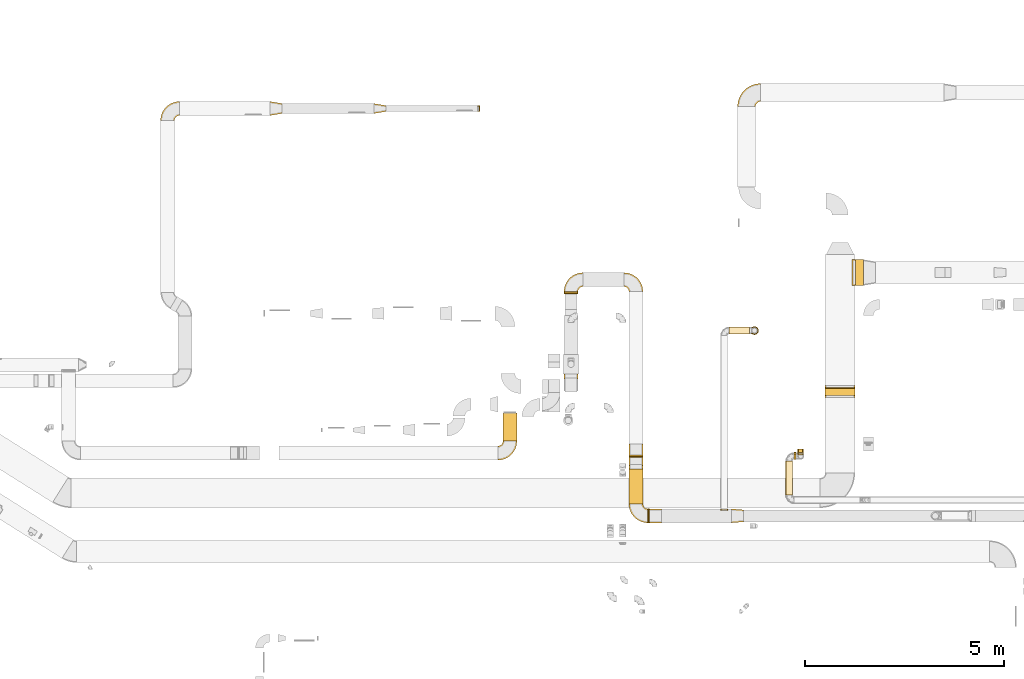
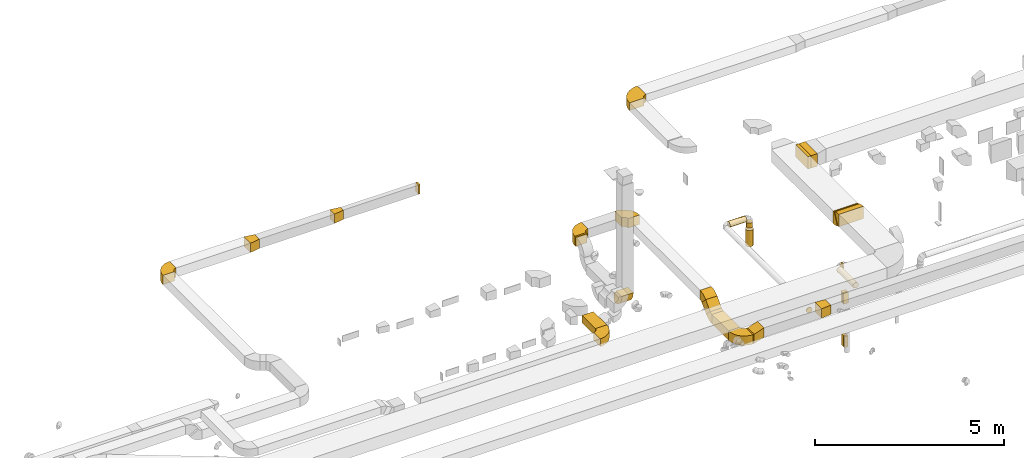
# One storey, part 6 of 97: 34 coverings.
"""IFC2X3 building model written with IfcOpenShell, lengths in millimetres."""

from ifc_helpers import new_model, entity, si_unit, converted_unit, derived_unit, direction, frame, frame_2d, origin, origin_2d_with_axis, place, context, subcontext, project, spatial, polyline, circle_curve, parameter, trimmed, segment, composite_curve, rectangle, circle, outline, extrude, element, save


model = new_model("IFC2X3")

# Units and contexts
model_context = context("Model", 3, precision=0.01, world=origin(), true_north=direction((6.12303176911189e-17, 1.0)))
body_context = subcontext(model_context, "Body", "Model", "MODEL_VIEW")
ifc_project = project(units=[si_unit("LENGTHUNIT", "METRE", prefix="MILLI"), si_unit("AREAUNIT", "SQUARE_METRE"), si_unit("VOLUMEUNIT", "CUBIC_METRE"), converted_unit("PLANEANGLEUNIT", "DEGREE", entity("IfcRatioMeasure", 0.0174532925199433), si_unit("PLANEANGLEUNIT", "RADIAN"), dimensions=[0, 0, 0, 0, 0, 0, 0]), si_unit("MASSUNIT", "GRAM", prefix="KILO"), derived_unit("MASSDENSITYUNIT", [(si_unit("MASSUNIT", "GRAM", prefix="KILO"), 1), (si_unit("LENGTHUNIT", "METRE"), -3)]), derived_unit("MOMENTOFINERTIAUNIT", [(si_unit("LENGTHUNIT", "METRE"), 4)]), si_unit("TIMEUNIT", "SECOND"), si_unit("FREQUENCYUNIT", "HERTZ"), si_unit("THERMODYNAMICTEMPERATUREUNIT", "DEGREE_CELSIUS"), derived_unit("THERMALTRANSMITTANCEUNIT", [(si_unit("MASSUNIT", "GRAM", prefix="KILO"), 1), (si_unit("THERMODYNAMICTEMPERATUREUNIT", "KELVIN"), -1), (si_unit("TIMEUNIT", "SECOND"), -3)]), derived_unit("VOLUMETRICFLOWRATEUNIT", [(si_unit("LENGTHUNIT", "METRE"), 3), (si_unit("TIMEUNIT", "SECOND"), -1)]), derived_unit("MASSFLOWRATEUNIT", [(si_unit("MASSUNIT", "GRAM", prefix="KILO"), 1), (si_unit("TIMEUNIT", "SECOND"), -1)]), derived_unit("ROTATIONALFREQUENCYUNIT", [(si_unit("TIMEUNIT", "SECOND"), -1)]), si_unit("ELECTRICCURRENTUNIT", "AMPERE"), si_unit("ELECTRICVOLTAGEUNIT", "VOLT"), si_unit("POWERUNIT", "WATT"), si_unit("FORCEUNIT", "NEWTON", prefix="KILO"), si_unit("ILLUMINANCEUNIT", "LUX"), si_unit("LUMINOUSFLUXUNIT", "LUMEN"), si_unit("LUMINOUSINTENSITYUNIT", "CANDELA"), derived_unit("USERDEFINED", [(si_unit("MASSUNIT", "GRAM", prefix="KILO"), -1), (si_unit("LENGTHUNIT", "METRE"), -2), (si_unit("TIMEUNIT", "SECOND"), 3), (si_unit("LUMINOUSFLUXUNIT", "LUMEN"), 1)]), derived_unit("LINEARVELOCITYUNIT", [(si_unit("LENGTHUNIT", "METRE"), 1), (si_unit("TIMEUNIT", "SECOND"), -1)]), si_unit("PRESSUREUNIT", "PASCAL"), derived_unit("USERDEFINED", [(si_unit("LENGTHUNIT", "METRE"), -2), (si_unit("MASSUNIT", "GRAM", prefix="KILO"), 1), (si_unit("TIMEUNIT", "SECOND"), -2)]), derived_unit("LINEARFORCEUNIT", [(si_unit("MASSUNIT", "GRAM", prefix="KILO"), 1), (si_unit("LENGTHUNIT", "METRE"), 1), (si_unit("TIMEUNIT", "SECOND"), -2), (si_unit("LENGTHUNIT", "METRE"), -1)]), derived_unit("PLANARFORCEUNIT", [(si_unit("MASSUNIT", "GRAM", prefix="KILO"), 1), (si_unit("LENGTHUNIT", "METRE"), 1), (si_unit("TIMEUNIT", "SECOND"), -2), (si_unit("LENGTHUNIT", "METRE"), -2)])], contexts=[model_context])

# Site, building, storey
site_placement = place(None, origin())
site = spatial("IfcSite", under=ifc_project, at=site_placement, CompositionType="ELEMENT")
building_placement = place(site_placement, origin())
building = spatial("IfcBuilding", under=site, at=building_placement, CompositionType="ELEMENT")
storey_placement = place(building_placement, frame((0.0, 0.0, -4900.0)))
storey = spatial("IfcBuildingStorey", under=building, at=storey_placement, CompositionType="ELEMENT", Elevation=-4900.0)

# Coverings
covering_1_placement = place(storey_placement, frame((29852.45, 11120.0, 4025.0)))
element("IfcCovering", 1, at=covering_1_placement, inside=storey, PredefinedType="INSULATION", context=body_context, shape_type="SweptSolid", body=[
    extrude(rectangle(XDim=705.060213644064, YDim=349.999999999998, at=origin_2d_with_axis()), frame((175.0, 352.53, 0.0), z_axis=(0.0, 0.0, 1.0), x_axis=(0.0, 1.0, 0.0)), (0.0, 0.0, 1.0), 250.0),
])
covering_2_placement = place(storey_placement, frame((37934.51, 12268.51, 4049.19)))
element("IfcCovering", 2, at=covering_2_placement, inside=storey, PredefinedType="INSULATION", context=body_context, shape_type="SweptSolid", body=[
    extrude(rectangle(XDim=400.000000000001, YDim=33.3635880186563, at=frame_2d((0.0, 0.0), x_axis=(0.0, 1.0))), frame((0.0, 99.64, 188.31), z_axis=(1.0, 0.0, 0.0), x_axis=(0.0, -0.906307787036671, 0.422618261740653)), (0.0, 0.0, 1.0), 750.000000000003),
])
covering_3_placement = place(storey_placement, frame((24014.26, 19288.45, 3825.0)))
element("IfcCovering", 3, at=covering_3_placement, inside=storey, PredefinedType="INSULATION", context=body_context, shape_type="SweptSolid", body=[
    extrude(outline(polyline([(-176.73, -147.96), (127.41, -147.96), (168.51, 98.64), (-119.19, 197.28), (-176.73, -147.96)])), frame((150.0, 175.0, 0.0), z_axis=(0.0, 0.0, 1.0), x_axis=(0.986393923832179, 0.164398987305147, 0.0)), (0.0, 0.0, 1.0), 300.0),
])
covering_4_placement = place(storey_placement, frame((26614.66, 19338.45, 3825.0)))
element("IfcCovering", 4, at=covering_4_placement, inside=storey, PredefinedType="INSULATION", context=body_context, shape_type="SweptSolid", body=[
    extrude(outline(polyline([(-168.51, -98.64), (135.63, -98.64), (160.29, 49.32), (-127.41, 147.96), (-168.51, -98.64)])), frame((150.0, 125.0, 0.0), z_axis=(0.0, 0.0, 1.0), x_axis=(0.98639392383218, 0.16439898730514, 0.0)), (0.0, 0.0, 1.0), 300.0),
])
covering_5_placement = place(storey_placement, frame((29214.66, 19388.45, 3825.0)))
element("IfcCovering", 5, at=covering_5_placement, inside=storey, PredefinedType="INSULATION", context=body_context, shape_type="SweptSolid", body=[
    extrude(rectangle(XDim=50.0000000000016, YDim=149.999999999998, at=origin_2d_with_axis()), frame((25.0, 75.0, 0.0), z_axis=(0.0, 0.0, 1.0), x_axis=(-1.0, 0.0, 0.0)), (0.0, 0.0, 1.0), 300.0),
])
covering_6_placement = place(storey_placement, frame((35310.54, 9388.91, 3890.9)))
element("IfcCovering", 6, at=covering_6_placement, inside=storey, PredefinedType="INSULATION", context=body_context, shape_type="SweptSolid", body=[
    extrude(circle(Radius=87.5, at=origin_2d_with_axis()), frame((89.1, 0.0, 89.1), z_axis=(0.0, 1.0, 0.0), x_axis=(-1.0, 0.0, 0.0)), (0.0, 0.0, 1.0), 26.0960000000213),
])
covering_7_placement = place(storey_placement, frame((35524.64, 13803.01, 3890.9)))
element("IfcCovering", 7, at=covering_7_placement, inside=storey, PredefinedType="INSULATION", context=body_context, shape_type="SweptSolid", body=[
    extrude(circle(Radius=87.5, at=origin_2d_with_axis()), frame((0.0, 89.1, 89.1), z_axis=(1.0, 0.0, 0.0), x_axis=(0.0, 1.0, 0.0)), (0.0, 0.0, 1.0), 512.325703081815),
])
covering_8_placement = place(storey_placement, frame((36072.87, 13803.01, 3694.66)))
element("IfcCovering", 8, at=covering_8_placement, inside=storey, PredefinedType="INSULATION", context=body_context, shape_type="SweptSolid", body=[
    extrude(circle(Radius=87.5, at=origin_2d_with_axis()), frame((89.1, 89.1, 0.0), z_axis=(0.0, 0.0, 1.0), x_axis=(0.0, -1.0, 0.0)), (0.0, 0.0, 1.0), 160.338533839341),
])
covering_9_placement = place(storey_placement, frame((36055.37, 13785.51, 3100.0)))
element("IfcCovering", 9, at=covering_9_placement, inside=storey, PredefinedType="INSULATION", context=body_context, shape_type="SweptSolid", body=[
    extrude(circle(Radius=105.0, at=origin_2d_with_axis()), frame((106.6, 106.6, 0.0)), (0.0, 0.0, 1.0), 529.361466160666),
])
covering_10_placement = place(storey_placement, frame((37248.02, 10829.97, 2675.0)))
element("IfcCovering", 10, at=covering_10_placement, inside=storey, PredefinedType="INSULATION", context=body_context, shape_type="SweptSolid", body=[
    extrude(rectangle(XDim=94.9999971698445, YDim=150.000000000001, at=origin_2d_with_axis()), frame((75.0, 47.5, 0.0), z_axis=(0.0, 0.0, 1.0), x_axis=(0.0, 1.0, 0.0)), (0.0, 0.0, 1.0), 350.0),
])
covering_11_placement = place(storey_placement, frame((37273.02, 10817.47, 1275.0)))
element("IfcCovering", 11, at=covering_11_placement, inside=storey, PredefinedType="INSULATION", context=body_context, shape_type="SweptSolid", body=[
    extrude(rectangle(XDim=109.999997169915, YDim=100.000000000003, at=origin_2d_with_axis()), frame((50.0, 55.0, 0.0), z_axis=(0.0, 0.0, 1.0), x_axis=(0.0, 1.0, 0.0)), (0.0, 0.0, 1.0), 350.000000000001),
])
covering_12_placement = place(storey_placement, frame((37273.02, 10766.37, 1275.0)))
element("IfcCovering", 12, at=covering_12_placement, inside=storey, PredefinedType="INSULATION", context=body_context, shape_type="SweptSolid", body=[
    extrude(rectangle(XDim=100.000000000003, YDim=51.0960000000102, at=origin_2d_with_axis()), frame((50.0, 25.55, 0.0), z_axis=(0.0, 0.0, 1.0), x_axis=(-1.0, 0.0, 0.0)), (0.0, 0.0, 1.0), 350.0),
])
covering_13_placement = place(storey_placement, frame((37248.02, 10778.87, 2675.0)))
element("IfcCovering", 13, at=covering_13_placement, inside=storey, PredefinedType="INSULATION", context=body_context, shape_type="SweptSolid", body=[
    extrude(rectangle(XDim=150.000000000001, YDim=51.0960000001488, at=origin_2d_with_axis()), frame((75.0, 25.55, 0.0), z_axis=(0.0, 0.0, 1.0), x_axis=(-1.0, 0.0, 0.0)), (0.0, 0.0, 1.0), 350.0),
])
covering_14_placement = place(storey_placement, frame((33013.7, 9545.01, 3750.0)))
element("IfcCovering", 14, at=covering_14_placement, inside=storey, PredefinedType="INSULATION", context=body_context, shape_type="SweptSolid", body=[
    extrude(rectangle(XDim=879.743529057647, YDim=349.999999999998, at=origin_2d_with_axis()), frame((175.0, 439.87, 0.0), z_axis=(0.0, 0.0, 1.0), x_axis=(0.0, -1.0, 0.0)), (0.0, 0.0, 1.0), 300.0),
])
covering_15_placement = place(storey_placement, frame((33013.7, 10513.14, 3874.48)))
element("IfcCovering", 15, at=covering_15_placement, inside=storey, PredefinedType="INSULATION", context=body_context, shape_type="SweptSolid", body=[
    extrude(rectangle(XDim=337.868000999336, YDim=299.999999999999, at=origin_2d_with_axis()), frame((0.0, 225.52, 225.52), z_axis=(1.0, 0.0, 0.0), x_axis=(0.0, -0.70710678118652, -0.707106781186575)), (0.0, 0.0, 1.0), 349.999999999998),
])
covering_16_placement = place(storey_placement, frame((37158.02, 10658.37, 3890.9)))
element("IfcCovering", 16, at=covering_16_placement, inside=storey, PredefinedType="INSULATION", context=body_context, shape_type="SweptSolid", body=[
    extrude(circle(Radius=87.5, at=origin_2d_with_axis()), frame((0.0, 89.1, 89.1), z_axis=(1.0, 0.0, 0.0), x_axis=(0.0, 1.0, 0.0)), (0.0, 0.0, 1.0), 39.9999999999649),
])
covering_17_placement = place(storey_placement, frame((36943.93, 9768.15, 3890.9)))
element("IfcCovering", 17, at=covering_17_placement, inside=storey, PredefinedType="INSULATION", context=body_context, shape_type="SweptSolid", body=[
    extrude(circle(Radius=87.5, at=origin_2d_with_axis()), frame((89.1, 0.0, 89.1), z_axis=(0.0, 1.0, 0.0), x_axis=(1.0, 0.0, 0.0)), (0.0, 0.0, 1.0), 854.321482830159),
])
covering_18_placement = place(storey_placement, frame((31385.22, 14819.99, 4150.0)))
element("IfcCovering", 18, at=covering_18_placement, inside=storey, PredefinedType="INSULATION", context=body_context, shape_type="SweptSolid", body=[
    extrude(rectangle(XDim=49.1921251237158, YDim=349.999999999998, at=origin_2d_with_axis()), frame((175.0, 24.6, 0.0), z_axis=(0.0, 0.0, 1.0), x_axis=(0.0, 1.0, 0.0)), (0.0, 0.0, 1.0), 300.0),
])
covering_19_placement = place(storey_placement, frame((35587.72, 9070.01, 3850.0)))
element("IfcCovering", 19, at=covering_19_placement, inside=storey, PredefinedType="INSULATION", context=body_context, shape_type="SweptSolid", body=[
    extrude(outline(polyline([(-137.03, -161.94), (164.01, -161.94), (134.95, 186.85), (-161.94, 137.03), (-137.03, -161.94)])), frame((150.0, 175.0, 0.0), z_axis=(0.0, 0.0, 1.0), x_axis=(-0.996545758244861, 0.0830454798539603, 0.0)), (0.0, 0.0, 1.0), 300.0),
])
covering_20_placement = place(storey_placement, frame((33527.72, 9070.01, 3750.0)))
element("IfcCovering", 20, at=covering_20_placement, inside=storey, PredefinedType="INSULATION", context=body_context, shape_type="SweptSolid", body=[
    extrude(outline(polyline([(-110.68, -142.3), (205.55, -142.3), (110.68, 142.3), (-205.55, 142.3), (-110.68, -142.3)])), frame((150.0, 0.0, 200.0), z_axis=(0.0, 1.0, 0.0), x_axis=(-0.948683298050474, 0.0, -0.316227766016957)), (0.0, 0.0, 1.0), 350.000000000001),
])
covering_21_placement = place(storey_placement, frame((33488.7, 9070.01, 3750.0)))
element("IfcCovering", 21, at=covering_21_placement, inside=storey, PredefinedType="INSULATION", context=body_context, shape_type="SweptSolid", body=[
    extrude(rectangle(XDim=39.0201967499437, YDim=350.000000000001, at=origin_2d_with_axis()), frame((19.51, 175.0, 0.0), z_axis=(0.0, 0.0, 1.0), x_axis=(-1.0, 0.0, 0.0)), (0.0, 0.0, 1.0), 300.0),
])
covering_22_placement = place(storey_placement, frame((38699.17, 15024.1, 4000.0)))
element("IfcCovering", 22, at=covering_22_placement, inside=storey, PredefinedType="INSULATION", context=body_context, shape_type="SweptSolid", body=[
    extrude(rectangle(XDim=196.431086282812, YDim=650.0, at=origin_2d_with_axis()), frame((98.22, 325.0, 0.0)), (0.0, 0.0, 1.0), 400.0),
])
covering_23_placement = place(storey_placement, frame((38608.74, 15024.1, 4000.0)))
element("IfcCovering", 23, at=covering_23_placement, inside=storey, PredefinedType="INSULATION", context=body_context, shape_type="SweptSolid", body=[
    extrude(rectangle(XDim=650.0, YDim=90.4326874347202, at=origin_2d_with_axis()), frame((45.22, 325.0, 0.0), z_axis=(0.0, 0.0, 1.0), x_axis=(0.0, 1.0, 0.0)), (0.0, 0.0, 1.0), 400.0),
])
covering_24_placement = place(storey_placement, frame((37934.51, 12214.08, 4061.69)))
element("IfcCovering", 24, at=covering_24_placement, inside=storey, PredefinedType="INSULATION", context=body_context, shape_type="SweptSolid", body=[
    extrude(outline(composite_curve([segment(polyline([(-184.78, -68.68), (215.22, -68.68)]), True, "CONTINUOUS"), segment(trimmed(circle_curve(frame_2d((-309.78, -68.68), x_axis=(0.906307787036667, 0.422618261740695)), 525.0), [parameter(335.0)], [parameter(0.0)], True, "PARAMETER"), True, "CONTINUOUS"), segment(polyline([(166.04, 153.2), (-196.49, -15.85)]), True, "CONTINUOUS"), segment(trimmed(circle_curve(frame_2d((-309.78, -68.68), x_axis=(0.906307787036667, 0.422618261740695)), 125.0), [parameter(335.0)], [parameter(360.0)], True, "PARAMETER"), False, "CONTINUOUS")], self_intersect=False)), frame((0.0, 70.27, 198.08), z_axis=(1.0, 0.0, 0.0), x_axis=(0.0, 0.422618261740699, 0.90630778703665)), (0.0, 0.0, 1.0), 750.000000000003),
])
covering_25_placement = place(storey_placement, frame((37934.51, 12297.15, 3998.4)))
element("IfcCovering", 25, at=covering_25_placement, inside=storey, PredefinedType="INSULATION", context=body_context, shape_type="SweptSolid", body=[
    extrude(outline(composite_curve([segment(polyline([(-196.49, 15.85), (166.04, -153.2)]), True, "CONTINUOUS"), segment(trimmed(circle_curve(frame_2d((-309.78, 68.68), x_axis=(1.0, 0.0)), 525.0), [parameter(335.0)], [parameter(0.0)], True, "PARAMETER"), True, "CONTINUOUS"), segment(polyline([(215.22, 68.68), (-184.78, 68.68)]), True, "CONTINUOUS"), segment(trimmed(circle_curve(frame_2d((-309.78, 68.68), x_axis=(1.0, 0.0)), 125.0), [parameter(335.0)], [parameter(360.0)], True, "PARAMETER"), False, "CONTINUOUS")], self_intersect=False)), frame((0.0, 154.79, 216.82), z_axis=(-1.0, 0.0, 0.0), x_axis=(0.0, -0.422618261741052, -0.906307787036486)), (0.0, 0.0, -1.0), 750.000000000003),
])
covering_26_placement = place(storey_placement, frame((35737.91, 19512.2, 4175.0)))
element("IfcCovering", 26, at=covering_26_placement, inside=storey, PredefinedType="INSULATION", context=body_context, shape_type="SweptSolid", body=[
    extrude(outline(composite_curve([segment(polyline([(-175.0, 50.0), (-175.0, -400.0)]), True, "CONTINUOUS"), segment(trimmed(circle_curve(frame_2d((-175.0, 175.0), x_axis=(1.0, 0.0)), 575.0), [parameter(270.0)], [parameter(0.0)], True, "PARAMETER"), True, "CONTINUOUS"), segment(polyline([(400.0, 175.0), (-50.0, 175.0)]), True, "CONTINUOUS"), segment(trimmed(circle_curve(frame_2d((-175.0, 175.0), x_axis=(1.0, 0.0)), 125.0), [parameter(270.0)], [parameter(360.0)], True, "PARAMETER"), False, "CONTINUOUS")], self_intersect=False)), frame((401.6, 176.6, 0.0), z_axis=(0.0, 0.0, -1.0), x_axis=(0.0, 1.0, 0.0)), (0.0, 0.0, -1.0), 250.0),
])
covering_27_placement = place(storey_placement, frame((21262.6, 19161.85, 3825.0)))
element("IfcCovering", 27, at=covering_27_placement, inside=storey, PredefinedType="INSULATION", context=body_context, shape_type="SweptSolid", body=[
    extrude(outline(composite_curve([segment(polyline([(-150.0, 25.0), (-150.0, -325.0)]), True, "CONTINUOUS"), segment(trimmed(circle_curve(frame_2d((-150.0, 150.0), x_axis=(1.0, 0.0)), 475.0), [parameter(270.0)], [parameter(0.0)], True, "PARAMETER"), True, "CONTINUOUS"), segment(polyline([(325.0, 150.0), (-25.0, 150.0)]), True, "CONTINUOUS"), segment(trimmed(circle_curve(frame_2d((-150.0, 150.0), x_axis=(1.0, 0.0)), 125.0), [parameter(270.0)], [parameter(360.0)], True, "PARAMETER"), False, "CONTINUOUS")], self_intersect=False)), frame((326.6, 151.6, 0.0), z_axis=(0.0, 0.0, -1.0), x_axis=(0.0, 1.0, 0.0)), (0.0, 0.0, -1.0), 300.0),
])
covering_28_placement = place(storey_placement, frame((29725.85, 10643.4, 4025.0)))
element("IfcCovering", 28, at=covering_28_placement, inside=storey, PredefinedType="INSULATION", context=body_context, shape_type="SweptSolid", body=[
    extrude(outline(composite_curve([segment(polyline([(-150.0, 25.0), (-150.0, -325.0)]), True, "CONTINUOUS"), segment(trimmed(circle_curve(frame_2d((-150.0, 150.0), x_axis=(1.0, 0.0)), 475.0), [parameter(270.0)], [parameter(0.0)], True, "PARAMETER"), True, "CONTINUOUS"), segment(polyline([(325.0, 150.0), (-25.0, 150.0)]), True, "CONTINUOUS"), segment(trimmed(circle_curve(frame_2d((-150.0, 150.0), x_axis=(1.0, 0.0)), 125.0), [parameter(270.0)], [parameter(360.0)], True, "PARAMETER"), False, "CONTINUOUS")], self_intersect=False)), frame((151.6, 326.6, 0.0), z_axis=(0.0, 0.0, -1.0), x_axis=(0.0, -1.0, 0.0)), (0.0, 0.0, -1.0), 250.0),
])
covering_29_placement = place(storey_placement, frame((33013.7, 10750.45, 4111.79)))
element("IfcCovering", 29, at=covering_29_placement, inside=storey, PredefinedType="INSULATION", context=body_context, shape_type="SweptSolid", body=[
    extrude(outline(composite_curve([segment(polyline([(-146.34, 8.84), (65.79, -203.29)]), True, "CONTINUOUS"), segment(trimmed(circle_curve(frame_2d((-234.73, 97.23), x_axis=(1.0, 0.0)), 425.0), [parameter(315.0)], [parameter(0.0)], True, "PARAMETER"), True, "CONTINUOUS"), segment(polyline([(190.27, 97.23), (-109.73, 97.23)]), True, "CONTINUOUS"), segment(trimmed(circle_curve(frame_2d((-234.73, 97.23), x_axis=(1.0, 0.0)), 125.0), [parameter(315.0)], [parameter(360.0)], True, "PARAMETER"), False, "CONTINUOUS")], self_intersect=False)), frame((0.0, 204.89, 147.93), z_axis=(-1.0, 0.0, 0.0), x_axis=(0.0, 0.0, 1.0)), (0.0, 0.0, -1.0), 349.999999999998),
])
covering_30_placement = place(storey_placement, frame((31385.22, 12373.39, 3588.4)))
element("IfcCovering", 30, at=covering_30_placement, inside=storey, PredefinedType="INSULATION", context=body_context, shape_type="SweptSolid", body=[
    extrude(outline(composite_curve([segment(polyline([(-137.5, 12.5), (-137.5, -287.5)]), True, "CONTINUOUS"), segment(trimmed(circle_curve(frame_2d((-137.5, 137.5), x_axis=(1.0, 0.0)), 425.0), [parameter(270.000000692248)], [parameter(0.0)], True, "PARAMETER"), True, "CONTINUOUS"), segment(polyline([(287.5, 137.5), (-12.5, 137.5)]), True, "CONTINUOUS"), segment(trimmed(circle_curve(frame_2d((-137.5, 137.5), x_axis=(1.0, 0.0)), 125.0), [parameter(270.000000692248)], [parameter(360.0)], True, "PARAMETER"), False, "CONTINUOUS")], self_intersect=False)), frame((0.0, 289.1, 289.1), z_axis=(-1.0, 0.0, -2.94447184401025e-05), x_axis=(0.0, -1.0, 0.0)), (0.0, 0.0, -1.0), 349.999999999999),
])
covering_31_placement = place(storey_placement, frame((32887.11, 14867.59, 4150.0)))
element("IfcCovering", 31, at=covering_31_placement, inside=storey, PredefinedType="INSULATION", context=body_context, shape_type="SweptSolid", body=[
    extrude(outline(composite_curve([segment(polyline([(-150.0, 25.0), (-150.0, -325.0)]), True, "CONTINUOUS"), segment(trimmed(circle_curve(frame_2d((-150.0, 150.0), x_axis=(1.0, 0.0)), 475.0), [parameter(270.0)], [parameter(0.0)], True, "PARAMETER"), True, "CONTINUOUS"), segment(polyline([(325.0, 150.0), (-25.0, 150.0)]), True, "CONTINUOUS"), segment(trimmed(circle_curve(frame_2d((-150.0, 150.0), x_axis=(1.0, 0.0)), 125.0), [parameter(270.0)], [parameter(360.0)], True, "PARAMETER"), False, "CONTINUOUS")], self_intersect=False)), frame((151.6, 151.6, 0.0), z_axis=(1.53428663483707e-08, 0.0, -1.0), x_axis=(1.0, 0.0, 1.53428663483707e-08)), (0.0, 0.0, -1.0), 300.0),
])
covering_32_placement = place(storey_placement, frame((31383.63, 14867.59, 4150.0)))
element("IfcCovering", 32, at=covering_32_placement, inside=storey, PredefinedType="INSULATION", context=body_context, shape_type="SweptSolid", body=[
    extrude(outline(composite_curve([segment(polyline([(-150.0, 25.0), (-150.0, -325.0)]), True, "CONTINUOUS"), segment(trimmed(circle_curve(frame_2d((-150.0, 150.0), x_axis=(1.0, 0.0)), 475.0), [parameter(270.0)], [parameter(0.0)], True, "PARAMETER"), True, "CONTINUOUS"), segment(polyline([(325.0, 150.0), (-25.0, 150.0)]), True, "CONTINUOUS"), segment(trimmed(circle_curve(frame_2d((-150.0, 150.0), x_axis=(1.0, 0.0)), 125.0), [parameter(270.0)], [parameter(360.0)], True, "PARAMETER"), False, "CONTINUOUS")], self_intersect=False)), frame((326.6, 151.6, 0.0), z_axis=(1.53428668330859e-08, 0.0, -1.0), x_axis=(0.0, 1.0, 0.0)), (0.0, 0.0, -1.0), 300.0),
])
covering_33_placement = place(storey_placement, frame((33013.7, 10423.15, 3748.4)))
element("IfcCovering", 33, at=covering_33_placement, inside=storey, PredefinedType="INSULATION", context=body_context, shape_type="SweptSolid", body=[
    extrude(outline(composite_curve([segment(polyline([(-109.73, -97.23), (190.27, -97.23)]), True, "CONTINUOUS"), segment(trimmed(circle_curve(frame_2d((-234.73, -97.23), x_axis=(0.707106781186553, 0.707106781186553)), 425.0), [parameter(315.0)], [parameter(0.0)], True, "PARAMETER"), True, "CONTINUOUS"), segment(polyline([(65.79, 203.29), (-146.34, -8.84)]), True, "CONTINUOUS"), segment(trimmed(circle_curve(frame_2d((-234.73, -97.23), x_axis=(0.707106781186553, 0.707106781186553)), 125.0), [parameter(315.0)], [parameter(360.0)], True, "PARAMETER"), False, "CONTINUOUS")], self_intersect=False)), frame((0.0, 98.82, 191.87), z_axis=(1.0, 0.0, 0.0), x_axis=(0.0, 0.0, -1.0)), (0.0, 0.0, 1.0), 349.999999999998),
])
covering_34_placement = place(storey_placement, frame((33012.11, 9068.41, 3750.0)))
element("IfcCovering", 34, at=covering_34_placement, inside=storey, PredefinedType="INSULATION", context=body_context, shape_type="SweptSolid", body=[
    extrude(outline(composite_curve([segment(polyline([(-150.0, 25.0), (-150.0, -325.0)]), True, "CONTINUOUS"), segment(trimmed(circle_curve(frame_2d((-150.0, 150.0), x_axis=(1.0, 0.0)), 475.0), [parameter(270.0)], [parameter(0.0)], True, "PARAMETER"), True, "CONTINUOUS"), segment(polyline([(325.0, 150.0), (-25.0, 150.0)]), True, "CONTINUOUS"), segment(trimmed(circle_curve(frame_2d((-150.0, 150.0), x_axis=(1.0, 0.0)), 125.0), [parameter(270.0)], [parameter(360.0)], True, "PARAMETER"), False, "CONTINUOUS")], self_intersect=False)), frame((326.6, 326.6, 0.0), z_axis=(0.0, 0.0, -1.0), x_axis=(-1.0, 0.0, 0.0)), (0.0, 0.0, -1.0), 300.0),
])

save(model, "model.ifc")
